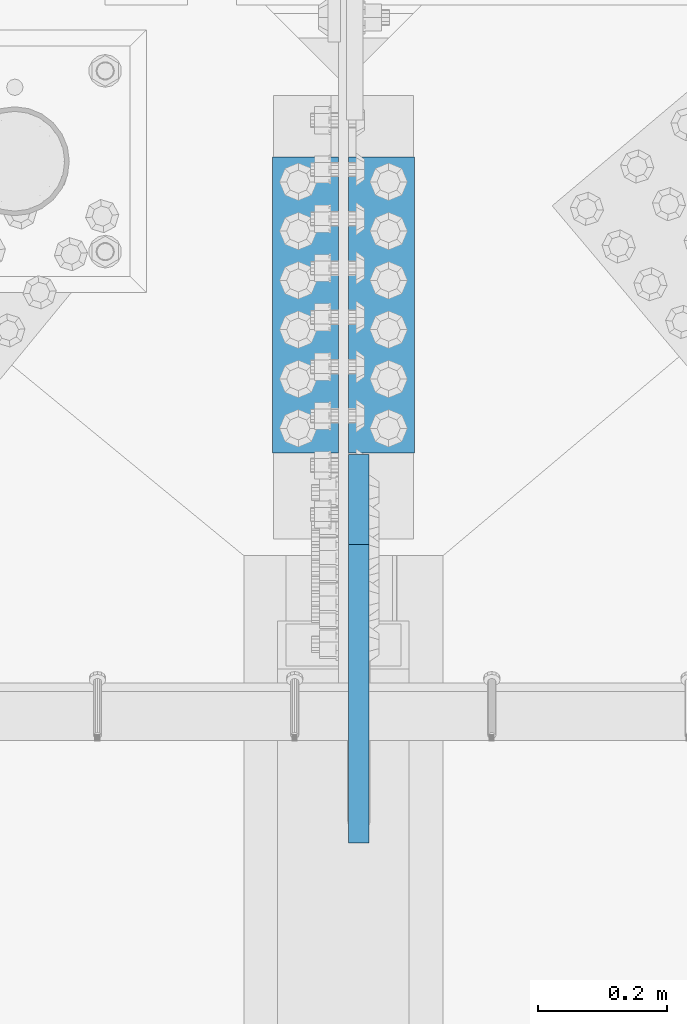
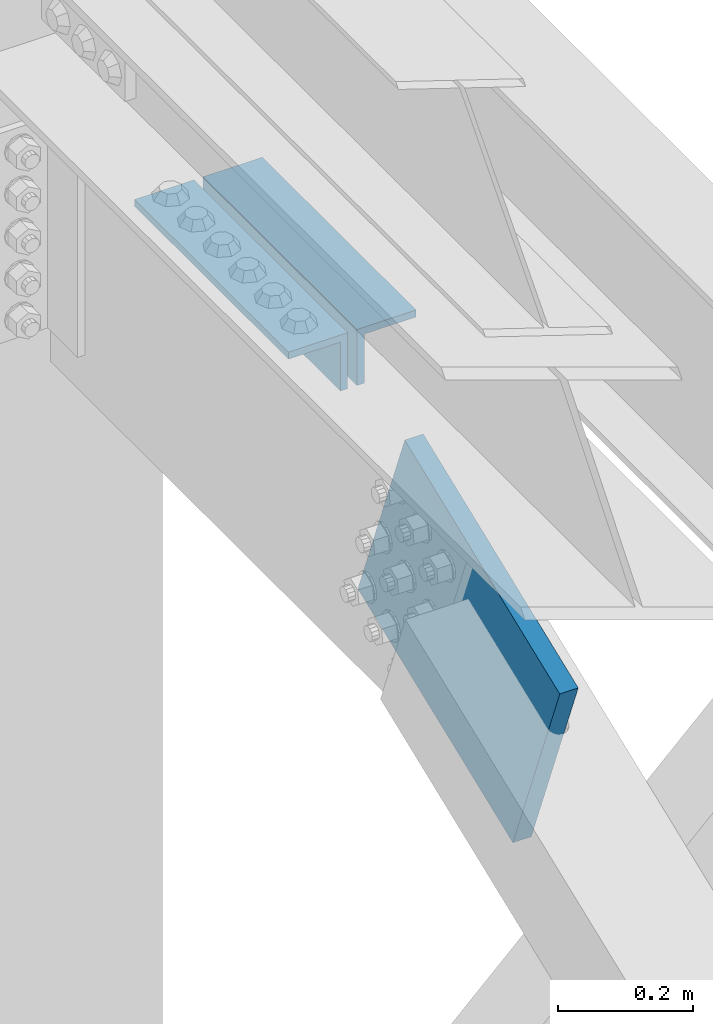
# One storey, part 2499 of 3843: 2 beams, 1 member, 2 elements without a shape of their own.
"""IFC2X3 building model written with IfcOpenShell, lengths in millimetres."""

from ifc_helpers import new_model, si_unit, frame, origin_with_axes, place, context, subcontext, project, spatial, faceted_brep, material, type_object, element, aggregate, save


model = new_model("IFC2X3")

# Units and contexts
model_context = context("Model", 3, precision=1e-05, world=origin_with_axes())
body_context = subcontext(model_context, "Body", "Model", "MODEL_VIEW")
ifc_project = project(units=[si_unit("LENGTHUNIT", "METRE", prefix="MILLI"), si_unit("AREAUNIT", "SQUARE_METRE"), si_unit("VOLUMEUNIT", "CUBIC_METRE"), si_unit("MASSUNIT", "GRAM", prefix="KILO"), si_unit("TIMEUNIT", "SECOND"), si_unit("PLANEANGLEUNIT", "RADIAN"), si_unit("SOLIDANGLEUNIT", "STERADIAN"), si_unit("THERMODYNAMICTEMPERATUREUNIT", "DEGREE_CELSIUS"), si_unit("LUMINOUSINTENSITYUNIT", "LUMEN")], contexts=[model_context])

# Site, building, storey
site_placement = place(None, origin_with_axes())
site = spatial("IfcSite", under=ifc_project, at=site_placement, CompositionType="ELEMENT")
building_placement = place(site_placement, origin_with_axes())
building = spatial("IfcBuilding", under=site, at=building_placement, Name="Undefined", CompositionType="ELEMENT")
storey_placement = place(building_placement, origin_with_axes())
storey = spatial("IfcBuildingStorey", under=building, at=storey_placement, Name="Undefined", CompositionType="ELEMENT", Elevation=0.0)

# Assembly, beams
assembly_1_placement = place(storey_placement, origin_with_axes())
assembly_1 = element("IfcElementAssembly", 1, at=assembly_1_placement, inside=storey, Name="PLATE", AssemblyPlace="NOTDEFINED", PredefinedType="RIGID_FRAME")
ifc_material = material(Name="STEEL/A572-50")
beam_type = type_object("IfcBeamType", Name="L4X4X1/2", PredefinedType="NOTDEFINED")
beam_1_placement = place(assembly_1_placement, frame((49055.3375, 91611.4500000032, 45285.4646632948), z_axis=(0.0, 0.0, -1.0), x_axis=(0.0, -1.0, 0.0)))
beam_1 = element("IfcBeam", 2, at=beam_1_placement, type_object=beam_type, material=ifc_material, Name="ANGLE", ObjectType="L4X4X1/2", context=body_context, shape_type="Brep", body=[
    faceted_brep([(0.0, 50.8000000000029, -50.8000000000029), (0.0, 50.8000000000029, 50.8000000000029), (457.199999999997, 50.8000000000029, 50.8000000000029), (457.199999999997, 50.8000000000029, -50.8000000000029), (0.0, 38.0999999999985, 50.8000000000029), (457.199999999997, 38.0999999999985, 50.8000000000029), (0.0, 38.0999999999985, -38.0999999999985), (457.199999999997, 38.0999999999985, -38.0999999999985), (0.0, -50.8000000000029, -38.1000000000058), (457.199999999997, -50.8000000000029, -38.0999999999985), (0.0, -50.8000000000029, -50.8000000000029), (457.199999999997, -50.8000000000029, -50.8000000000029)], [[[0, 1, 2, 3]], [[1, 4, 5, 2]], [[4, 6, 7, 5]], [[6, 8, 9, 7]], [[8, 10, 11, 9]], [[10, 0, 3, 11]], [[5, 7, 9, 11, 3, 2]], [[10, 8, 6, 4, 1, 0]]]),
])
beam_2_placement = place(assembly_1_placement, frame((48937.8625, 91154.2500000032, 45285.4646633281), z_axis=(0.0, 0.0, -1.0), x_axis=(0.0, 1.0, 0.0)))
beam_2 = element("IfcBeam", 3, at=beam_2_placement, type_object=beam_type, material=ifc_material, Name="ANGLE", ObjectType="L4X4X1/2", context=body_context, shape_type="Brep", body=[
    faceted_brep([(0.0, 50.8000000000029, -50.8000000000029), (0.0, 50.8000000000029, 50.8000000000029), (457.199999999997, 50.8000000000029, 50.8000000000029), (457.199999999997, 50.8000000000029, -50.8000000000029), (0.0, 38.0999999999985, 50.8000000000029), (457.199999999997, 38.0999999999985, 50.8000000000029), (0.0, 38.0999999999985, -38.0999999999985), (457.199999999997, 38.0999999999985, -38.0999999999985), (0.0, -50.8000000000029, -38.1000000000058), (457.199999999997, -50.8000000000029, -38.0999999999985), (0.0, -50.8000000000029, -50.8000000000029), (457.199999999997, -50.8000000000029, -50.8000000000029)], [[[0, 1, 2, 3]], [[1, 4, 5, 2]], [[4, 6, 7, 5]], [[6, 8, 9, 7]], [[8, 10, 11, 9]], [[10, 0, 3, 11]], [[5, 7, 9, 11, 3, 2]], [[10, 8, 6, 4, 1, 0]]]),
])
aggregate(assembly_1, [beam_1, beam_2])

# Assembly, member
assembly_2_placement = place(storey_placement, origin_with_axes())
assembly_2 = element("IfcElementAssembly", 4, at=assembly_2_placement, inside=storey, AssemblyPlace="NOTDEFINED", PredefinedType="RIGID_FRAME")
member_type = type_object("IfcMemberType", PredefinedType="NOTDEFINED")
member_placement = place(assembly_2_placement, frame((49020.4125, 91082.1715266957, 45044.6906014148), z_axis=(0.0, -0.366107652881532, 0.930572504698895), x_axis=(0.0, -0.930572504698893, -0.366107652881539)))
member = element("IfcMember", 5, at=member_placement, type_object=member_type, material=ifc_material, Name="PLATE", context=body_context, shape_type="Brep", body=[
    faceted_brep([(3.56521923094988e-10, 15.875, -190.500000000146), (-3.61978891305625e-10, 15.875, 190.500000000153), (495.299999995012, 15.875, 190.500000001084), (495.299999995726, 15.875, -190.499999999221), (-3.61978891305625e-10, -15.875, 190.500000000153), (495.299999995012, -15.875, 190.500000001084), (3.56521923094988e-10, -15.875, -190.500000000146), (495.299999995726, -15.875, -190.499999999221)], [[[0, 1, 2, 3]], [[1, 4, 5, 2]], [[4, 6, 7, 5]], [[6, 0, 3, 7]], [[5, 7, 3, 2]], [[6, 4, 1, 0]]]),
])
aggregate(assembly_2, [member])

save(model, "model.ifc")
